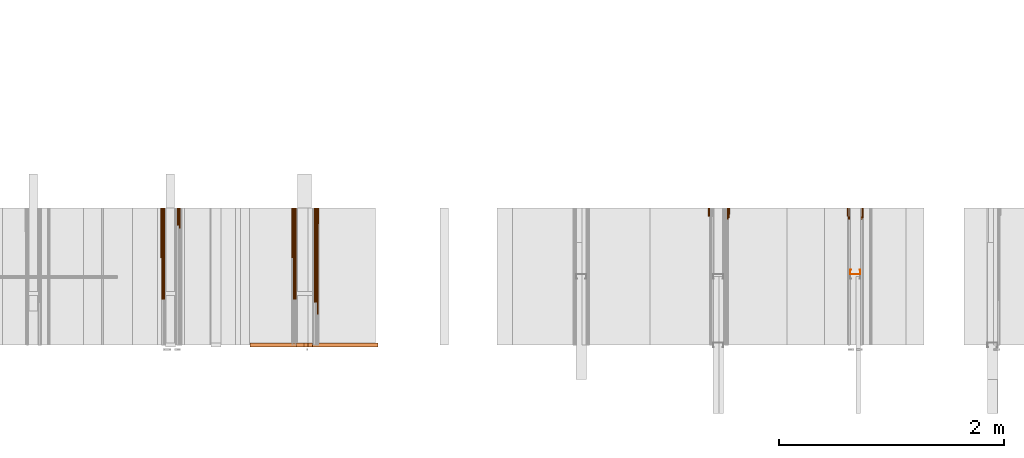
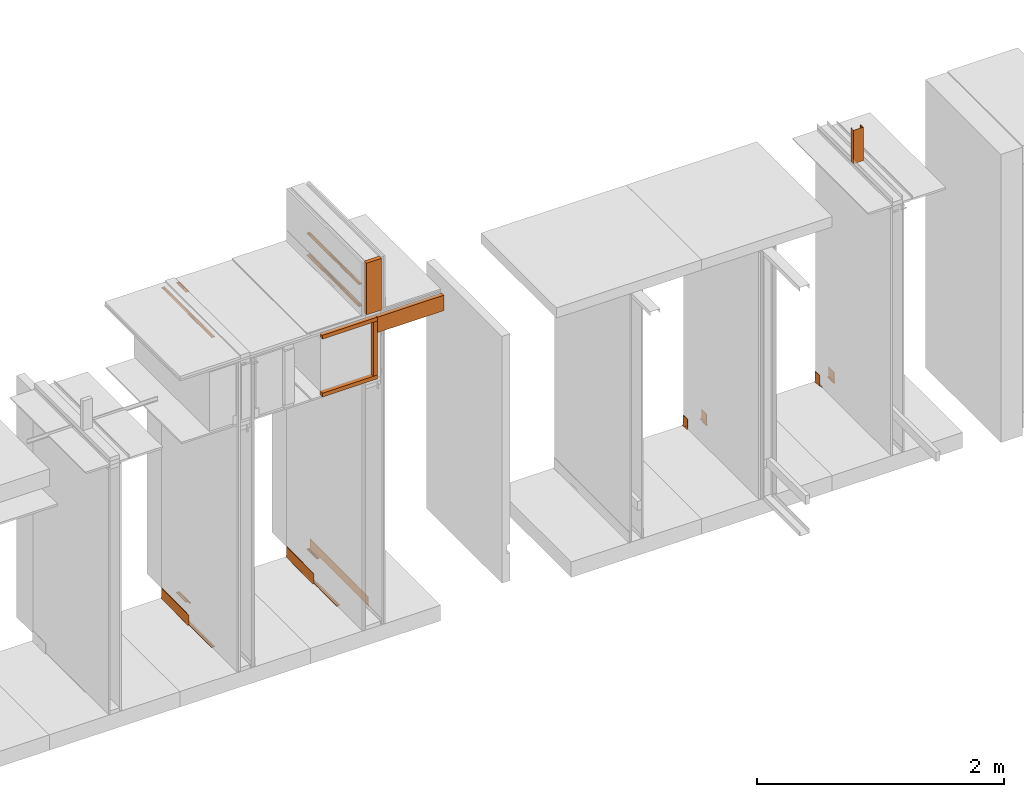
# One storey, part 18 of 38: 32 proxies.
"""IFC4 building model written with IfcOpenShell, lengths in feet."""

from ifc_helpers import new_model, entity, si_unit, converted_unit, frame, origin_with_axes, origin_2d_with_axis, place, context, subcontext, project, spatial, polyline, outline, extrude, material, element, save


model = new_model("IFC4")

# Units and contexts
model_context_1 = context("Model", 3, precision=1e-05, world=origin_with_axes())
plan_context = context("Plan", 2, precision=1e-05, world=origin_2d_with_axis())
model_context_2 = context("Model", 3, precision=1e-05, world=origin_with_axes())
context_of_model_1 = context(None, 3, precision=1e-05, world=origin_with_axes())
context_of_model_2 = context(None, 3, precision=1e-05, world=origin_with_axes())
body_context = subcontext(model_context_2, "Body", "Model", "MODEL_VIEW")
ifc_project = project(units=[converted_unit("PLANEANGLEUNIT", "degree", entity("IfcReal", 0.0174532925199433), si_unit("PLANEANGLEUNIT", "RADIAN"), dimensions=[0, 0, 0, 0, 0, 0, 0]), converted_unit("AREAUNIT", "square foot", entity("IfcReal", 0.09290304), si_unit("AREAUNIT", "SQUARE_METRE"), dimensions=[2, 0, 0, 0, 0, 0, 0]), converted_unit("LENGTHUNIT", "foot", entity("IfcReal", 0.3048), si_unit("LENGTHUNIT", "METRE"), dimensions=[1, 0, 0, 0, 0, 0, 0]), converted_unit("VOLUMEUNIT", "cubic foot", entity("IfcReal", 0.0283168467116885), si_unit("VOLUMEUNIT", "CUBIC_METRE"), dimensions=[3, 0, 0, 0, 0, 0, 0])], contexts=[model_context_1, plan_context, context_of_model_1, context_of_model_2])

# Site, building, storey
site_placement = place(None, origin_with_axes())
site = spatial("IfcSite", under=ifc_project, at=site_placement)
building_placement = place(site_placement, origin_with_axes())
building = spatial("IfcBuilding", under=site, at=building_placement, Name="Building")
storey_placement = place(building_placement, origin_with_axes())
storey = spatial("IfcBuildingStorey", under=building, at=storey_placement, Name="Storey")

# Proxies
for number, where, z_axis, x_axis, name in (
    (1, (1387.44344235718, 5.99999987860051, 9.53906242615908), (4.37113882867379e-08, -0.999999999999999, -8.51092183247426e-15), (1.94707183709394e-07, 0.0, 0.999999999999981), "Generic Models 484:Generic Models 1"),
    (2, (1387.39137824752, 5.99999987860051, 9.53906242615908), (4.37113882867379e-08, -0.999999999999999, -8.51092183247426e-15), (1.94707183709394e-07, 0.0, 0.999999999999981), "Generic Models 485:Generic Models 1"),
):
    element("IfcBuildingElementProxy", number, at=place(storey_placement, frame(where, z_axis=z_axis, x_axis=x_axis)), inside=storey, Name=name, PredefinedType="COMPLEX", context=body_context, shape_type="SweptSolid", body=[
        extrude(outline(polyline([(0.02006640513562, 2.44658686104459e-14), (0.010746400717773, 0.00652686703163065), (0.00925161041627367, 0.0178064079099675), (-0.0174579991570373, 0.00158422270586856), (-0.0159632096194181, -0.00969531779052822), (-0.00664320825709133, -0.0162221848221589), (0.02006640513562, 2.44658686104459e-14)])), frame((0.0104166711240596, -0.0185779741356575, -3.93321257744777e-07), z_axis=(-1.14723248262338e-12, 1.19208920068559e-07, -1.0), x_axis=(0.519110083580017, -0.854707419872284, -1.0188848875714e-07)), (4.71457262118946e-10, 6.21661333521928e-11, -1.0), 2.7499999222411),
    ])
proxy_1_placement = place(storey_placement, frame((1387.2083528774, 1.94270838433363, 9.55989589215577), z_axis=(0.999999999999997, 0.0, 7.54979012640431e-08), x_axis=(7.54979012640431e-08, 0.0, -0.999999999999997)))
element("IfcBuildingElementProxy", 3, at=proxy_1_placement, inside=storey, Name="Generic Models 489:Generic Models 1", PredefinedType="COMPLEX", context=body_context, shape_type="SweptSolid", body=[
    extrude(outline(polyline([(-0.0625000007724355, -0.250000003089742), (0.0625000007724355, -0.250000003089742), (0.0625000007724355, 0.250000003089742), (-0.0625000007724355, 0.250000003089742), (-0.0625000007724355, -0.250000003089742)])), frame((-0.250000003089742, 0.0625000007724355, 1.88745869327634e-08), z_axis=(-7.54979012640433e-08, 0.0, -1.0), x_axis=(0.0, -1.0, 0.0)), (0.0, 3.66200114676474e-09, -1.0), 2.04166679206452),
])
for number, where, z_axis, x_axis, name in (
    (4, (1387.44344235718, 5.99999987860051, 10.2500003466769), (4.37113882867379e-08, -0.999999999999999, -8.51092183247426e-15), (1.94707183709394e-07, 0.0, 0.999999999999981), "Generic Models 494:Generic Models 1"),
    (5, (1387.39137824752, 5.99999987860051, 10.2500003466769), (4.37113882867379e-08, -0.999999999999999, -8.51092183247426e-15), (1.94707183709394e-07, 0.0, 0.999999999999981), "Generic Models 495:Generic Models 1"),
):
    element("IfcBuildingElementProxy", number, at=place(storey_placement, frame(where, z_axis=z_axis, x_axis=x_axis)), inside=storey, Name=name, PredefinedType="COMPLEX", context=body_context, shape_type="SweptSolid", body=[
        extrude(outline(polyline([(0.02006640513562, 2.44658686104459e-14), (0.010746400717773, 0.00652686703163065), (0.00925161041627367, 0.0178064079099675), (-0.0174579991570373, 0.00158422270586856), (-0.0159632096194181, -0.00969531779052822), (-0.00664320825709133, -0.0162221848221589), (0.02006640513562, 2.44658686104459e-14)])), frame((0.0104166711240596, -0.0185779741356575, -3.93321257744777e-07), z_axis=(-1.14723248262338e-12, 1.19208920068559e-07, -1.0), x_axis=(0.519110083580017, -0.854707419872284, -1.0188848875714e-07)), (4.71457262118946e-10, 6.21661333521928e-11, -1.0), 2.7499999222411),
    ])
ifc_material_1 = material(Name="ACOUSTICAL SEALANT OR FIRE SEALANT, IF RATED WALL", Category="sealant")
proxy_2_placement = place(storey_placement, frame((1399.44341864799, 5.99999987860051, 0.0), z_axis=(4.37113882867379e-08, -0.999999999999999, -8.51092183247426e-15), x_axis=(1.94707183709394e-07, 0.0, 0.999999999999981)))
element("IfcBuildingElementProxy", 6, at=proxy_2_placement, inside=storey, material=ifc_material_1, Name="Generic Models 523:Generic Models 1", PredefinedType="COMPLEX", context=body_context, shape_type="SweptSolid", body=[
    extrude(outline(polyline([(0.0175297336061326, -7.63852336224064e-10), (-0.0076045238185586, 0.0185696447874344), (-0.0101125712342697, 0.0074713520236372), (-0.0199842910842085, 0.00181347399851029), (0.0051499686321229, -0.0167561736534743), (0.0150216877181816, -0.0110982950554374), (0.0175297336061326, -7.63852336224064e-10)])), frame((0.0104166703601796, -0.0185779726078973, -3.93321257744777e-07), z_axis=(1.60612517209613e-12, 1.19208898752277e-07, -1.0), x_axis=(0.594228446483612, 0.804296314716339, 9.58789314609021e-08)), (-2.02007854888109e-09, -9.08152775203064e-10, -1.0), 0.327715252322509),
])
ifc_material_2 = material(Name="WALL BASE AS SCHEDULED")
proxy_3_placement = place(storey_placement, frame((1399.47916266174, 5.99999987860051, 0.0), z_axis=(4.37113882867379e-08, -0.999999999999999, -8.51092183247426e-15), x_axis=(1.94707183709394e-07, 0.0, 0.999999999999981)))
element("IfcBuildingElementProxy", 7, at=proxy_3_placement, inside=storey, material=ifc_material_2, Name="Generic Models 524:Generic Models 1", PredefinedType="COMPLEX", context=body_context, shape_type="SweptSolid", body=[
    extrude(outline(polyline([(0.0865199099590616, -4.77471845963041e-10), (0.0968456312310039, -0.00715054454907697), (0.104968817391264, -0.0167299282622189), (0.113724960683994, -0.0110875258742883), (0.103843053729515, 0.000565862347658484), (0.0912817549498219, 0.00926454290576533), (0.0768970805672523, 0.0144157199961502), (0.0616693209240756, 0.0156683458034878), (-0.220639460043019, 0.00187364616797958), (-0.220465197611669, -0.00169230333231194), (-0.218225990145851, -0.00642984586076082), (-0.213292669358216, -0.00819646135544566), (0.0621777106066701, 0.00526409193181636), (0.0746953276687563, 0.00423440222965744), (0.0865199099590616, -4.77471845963041e-10)])), frame((0.113048297389755, -0.0126398416918035, -3.92613465797823e-07), z_axis=(2.34369598381412e-13, 1.19209985882662e-07, -1.0), x_axis=(-0.998808324337006, -0.0488058403134346, -5.81771075758297e-09)), (-0.020832484588027, 0.0165427997708321, -0.999646127223969), 0.287798682010875),
])
proxy_4_placement = place(storey_placement, frame((1398.89264044173, 5.99999987860051, 0.0), z_axis=(4.37113882867379e-08, -0.999999999999999, -8.51092183247426e-15), x_axis=(1.94707183709394e-07, 0.0, 0.999999999999981)))
element("IfcBuildingElementProxy", 8, at=proxy_4_placement, inside=storey, material=ifc_material_2, Name="Generic Models 535:Generic Models 1", PredefinedType="COMPLEX", context=body_context, shape_type="SweptSolid", body=[
    extrude(outline(polyline([(-0.220285068581423, -0.0126398630804453), (0.0623605284947423, -0.0126398630804453), (0.0775090034982664, -0.0106455280636181), (0.091625128205367, -0.00479843599166907), (0.10374691484012, 0.00450294273856568), (0.113048309611836, 0.0166247343385392), (0.10402720382442, 0.0218330687547489), (0.0963812288180424, 0.0118686390730242), (0.0864167983724376, 0.00422266101112633), (0.0748129713097269, -0.000583799731590128), (0.0623605223837018, -0.00222319424802589), (-0.213438576561572, -0.00222319291123578), (-0.218279791746553, -0.00422847681199726), (-0.220285068581423, -0.00906965876819463), (-0.220285068581423, -0.0126398630804453)])), frame((0.113048285167674, -0.0218330458383469, -3.93709398707717e-07), z_axis=(-1.27837871581951e-13, 1.19210028515226e-07, -1.0), x_axis=(-0.999999940395355, -1.94587727264661e-07, -3.29908111463065e-13)), (-0.0198198724538088, -0.0173815358430147, -0.999652445316315), 0.23873268911057),
])
ifc_material_3 = material(Name="ACOUSTICAL SEALANT", Category="sealant")
proxy_5_placement = place(storey_placement, frame((1403.34972872196, 5.99999987860051, 0.0), z_axis=(4.37113882867379e-08, -0.999999999999999, -8.51092183247426e-15), x_axis=(1.94707183709394e-07, 0.0, 0.999999999999981)))
element("IfcBuildingElementProxy", 9, at=proxy_5_placement, inside=storey, material=ifc_material_3, Name="Generic Models 554:Generic Models 1", PredefinedType="COMPLEX", context=body_context, shape_type="SweptSolid", body=[
    extrude(outline(polyline([(0.0175297320783725, -9.54822306813564e-10), (-0.00760452458243866, 0.0185696432596742), (-0.0101125689426295, 0.00747134591259668), (-0.0199842865009281, 0.00181346750552974), (0.00514996939600296, -0.0167561767089946), (0.0150216877181816, -0.0110982973470775), (0.0175297320783725, -9.54822306813564e-10)])), frame((0.0104166718879397, -0.0185779741356575, -3.93321257744777e-07), z_axis=(-2.29446507366698e-13, 1.19208912963131e-07, -1.0), x_axis=(0.594228386878967, 0.804296314716339, 9.58789314609021e-08)), (2.64177368869412e-09, -5.5714988178579e-09, -1.0), 0.327715252322509),
])
proxy_6_placement = place(storey_placement, frame((1402.97917243377, 5.99999987860051, 0.0), z_axis=(4.37113882867379e-08, -0.999999999999999, -8.51092183247426e-15), x_axis=(1.94707183709394e-07, 0.0, 0.999999999999981)))
element("IfcBuildingElementProxy", 10, at=proxy_6_placement, inside=storey, material=ifc_material_1, Name="Generic Models 608:Generic Models 1", PredefinedType="COMPLEX", context=body_context, shape_type="SweptSolid", body=[
    extrude(outline(polyline([(0.0175297320783725, 1.21721940269941e-09), (-0.00760452534631872, 0.0185696447874344), (-0.0101125697065096, 0.00747135049587707), (-0.0199842895564484, 0.00181347361657025), (0.0051499686321229, -0.0167561721257142), (0.0150216861904215, -0.0110982927637972), (0.0175297320783725, 1.21721940269941e-09)])), frame((0.0104166711240596, -0.0171509025657545, -2.04454727426466e-09), z_axis=(-2.15106117596939e-14, 1.19209289550781e-07, -1.0), x_axis=(-0.594228446483612, -0.804296314716339, -9.58795709493643e-08)), (8.53868475925168e-10, 9.09779973579106e-10, -1.0), 0.327715252322509),
])
ifc_material_4 = material(Name="METAL STUD BRACE TO DECK AS")
proxy_7_placement = place(storey_placement, frame((1403.03123654343, 4.06770842281852, 8.2030516909802), z_axis=(0.0, 0.0, 1.0), x_axis=(1.0, 0.0, 0.0)))
element("IfcBuildingElementProxy", 11, at=proxy_7_placement, inside=storey, material=ifc_material_4, Name="Generic Models 610:Generic Models 65", PredefinedType="COMPLEX", context=body_context, shape_type="SweptSolid", body=[
    extrude(outline(polyline([(0.157893092672187, 1.22220810316992e-08), (0.132981448231407, 0.00758804234228735), (0.131463832429701, 0.00260571100971517), (0.151393157759989, -0.00346471323922589), (0.114970610738583, -0.123040630846355), (-0.164039870552973, -0.0380546898334202), (-0.127617323531566, 0.081521225482069), (-0.107687998201278, 0.0754507989414877), (-0.106170394621653, 0.0804331302740599), (-0.131082002396189, 0.0880211481721852), (-0.170539756576846, -0.0415194298084483), (0.11843533849153, -0.129540565758552), (0.157893092672187, 1.22220810316992e-08)])), frame((0.15104167515368, 0.0894097232423586, 0.0), z_axis=(0.0, 0.0, -1.0), x_axis=(-0.956607341766357, 0.291380345821381, 0.0)), (2.82048029376369e-09, 2.82048029376369e-09, -1.0), 1.08333330786739),
])
proxy_8_placement = place(storey_placement, frame((1403.38537261242, 5.99999987860051, 0.0), z_axis=(4.37113882867379e-08, -0.999999999999999, -8.51092183247426e-15), x_axis=(1.94707183709394e-07, 0.0, 0.999999999999981)))
element("IfcBuildingElementProxy", 12, at=proxy_8_placement, inside=storey, material=ifc_material_2, Name="Generic Models 557:Generic Models 1", PredefinedType="COMPLEX", context=body_context, shape_type="SweptSolid", body=[
    extrude(outline(polyline([(0.103844581489644, 6.68348250758758e-10), (0.0913308632714073, 0.00876700184784654), (0.076974470784345, 0.0139964858114015), (0.0617537693929641, 0.015332072049262), (-0.220625991309722, 0.00307591050848599), (-0.220471186431374, -0.000490935787001229), (-0.21825784088902, -0.00524060834893404), (-0.213334248877886, -0.00703408110280597), (0.0622054608416526, 0.00492520150642969), (0.0747172785262892, 0.00382731679345425), (0.0865186083074317, -0.000471456558901934), (0.096805212809032, -0.00767816109289452), (0.104876076240396, -0.017301668046321), (0.113662848068191, -0.0117070593423848), (0.103844581489644, 6.68348250758758e-10)])), frame((0.113048285167674, -0.0126398416918035, -3.92613372550745e-07), z_axis=(-8.52252974139003e-14, 1.19210000093517e-07, -1.0), x_axis=(-0.9990593791008, -0.0433624871075153, -5.16948928108718e-09)), (-0.0207421220839024, 0.0166560765355825, -0.999646127223969), 0.287798682580641),
])
proxy_9_placement = place(storey_placement, frame((1382.9030515015, 5.99999987860051, 0.0), z_axis=(4.37113882867379e-08, -0.999999999999999, -8.51092183247426e-15), x_axis=(1.94707183709394e-07, 0.0, 0.999999999999981)))
element("IfcBuildingElementProxy", 13, at=proxy_9_placement, inside=storey, Name="Generic Models 247:Generic Models 1", PredefinedType="COMPLEX", context=body_context, shape_type="SweptSolid", body=[
    extrude(outline(polyline([(-0.0623605162726613, 0.00222319443899591), (0.213438576561572, 0.00222319443899591), (0.21827976730239, 0.00422847833975739), (0.220285068581423, 0.00906966029595476), (0.220285068581423, 0.0126398615526852), (-0.0623605162726613, 0.0126398600249251), (-0.0775089912761853, 0.0106455280636181), (-0.0916251159832859, 0.00479843599166907), (-0.103746902618039, -0.00450294121080555), (-0.113048285167674, -0.016624732810779), (-0.104027191602339, -0.0218330672269887), (-0.0963812104849208, -0.0118686375452641), (-0.0864167861503566, -0.0042226594833662), (-0.0748129590876459, 0.000583799922560144), (-0.0623605162726613, 0.00222319443899591)])), frame((0.113048285167674, -0.0218330443105868, -3.93709305460639e-07), z_axis=(4.2612652095082e-14, 1.1920982956326e-07, -1.0), x_axis=(1.0, 1.99418224156034e-07, 0.0)), (-0.00616074912250042, -0.000579560699407011, -0.999980926513672), 1.45644764653809),
])
proxy_10_placement = place(storey_placement, frame((1383.44341688582, 5.99999987860051, 10.0416664689232), z_axis=(4.37113882867379e-08, -0.999999999999999, -8.51092183247426e-15), x_axis=(1.94707183709394e-07, 0.0, 0.999999999999981)))
element("IfcBuildingElementProxy", 14, at=proxy_10_placement, inside=storey, Name="Generic Models 365:Generic Models 1", PredefinedType="COMPLEX", context=body_context, shape_type="SweptSolid", body=[
    extrude(outline(polyline([(0.0175297336061326, -4.44417714571301e-10), (0.0150216877181816, 0.0110982950554374), (0.00514996786824283, 0.0167561736534743), (-0.0199842910842085, -0.00181347495336037), (-0.0101125697065096, -0.00747135278751726), (-0.00760452458243866, -0.0185696478429546), (0.0175297336061326, -4.44417714571301e-10)])), frame((0.0104166718879397, -0.0185779726078973, -2.21466728012772e-09), z_axis=(-3.22659176395408e-14, 1.19209289550781e-07, -1.0), x_axis=(-0.594228804111481, 0.804296016693115, 9.58795780547916e-08)), (-0.000335803983034566, 0.000445228302851319, -0.999999821186066), 0.501448011219435),
])
proxy_11_placement = place(storey_placement, frame((1382.9374939125, 5.99999987860051, 10.0416664689232), z_axis=(4.37113882867379e-08, -0.999999999999999, -8.51092183247426e-15), x_axis=(1.94707183709394e-07, 0.0, 0.999999999999981)))
element("IfcBuildingElementProxy", 15, at=proxy_11_placement, inside=storey, Name="Generic Models 367:Generic Models 1", PredefinedType="COMPLEX", context=body_context, shape_type="SweptSolid", body=[
    extrude(outline(polyline([(0.0175297320783725, 1.21719171997307e-09), (-0.00760452534631872, 0.0185696447874344), (-0.0101125697065096, 0.00747135049587707), (-0.0199842895564484, 0.00181347361657025), (0.0051499686321229, -0.0167561721257142), (0.0150216861904215, -0.0110982927637972), (0.0175297320783725, 1.21719171997307e-09)])), frame((0.0104166711240596, -0.0171509025657545, -3.9315117507417e-07), z_axis=(1.14723269946382e-12, 1.19208550586336e-07, -1.0), x_axis=(-0.594228446483612, -0.804296314716339, -9.58762740310704e-08)), (-3.95444403693546e-05, -5.28345335624181e-05, -1.0), 2.66158480628663),
])
proxy_12_placement = place(storey_placement, frame((1383.39135277615, 5.99999987860051, 10.0416664689232), z_axis=(4.37113882867379e-08, -0.999999999999999, -8.51092183247426e-15), x_axis=(1.94707183709394e-07, 0.0, 0.999999999999981)))
element("IfcBuildingElementProxy", 16, at=proxy_12_placement, inside=storey, Name="Generic Models 373:Generic Models 1", PredefinedType="COMPLEX", context=body_context, shape_type="SweptSolid", body=[
    extrude(outline(polyline([(0.0175297336061326, -4.44417714571301e-10), (0.0150216877181816, 0.0110982950554374), (0.00514996786824283, 0.0167561736534743), (-0.0199842910842085, -0.00181347495336037), (-0.0101125697065096, -0.00747135278751726), (-0.00760452458243866, -0.0185696478429546), (0.0175297336061326, -4.44417714571301e-10)])), frame((0.0104166718879397, -0.0185779726078973, -2.21466728012772e-09), z_axis=(-3.22659176395408e-14, 1.19209289550781e-07, -1.0), x_axis=(-0.594228804111481, 0.804296016693115, 9.58795780547916e-08)), (-0.000335803983034566, 0.000445228302851319, -0.999999821186066), 0.501448011219435),
])
proxy_13_placement = place(storey_placement, frame((1382.98955802217, 5.99999987860051, 10.0416664689232), z_axis=(4.37113882867379e-08, -0.999999999999999, -8.51092183247426e-15), x_axis=(1.94707183709394e-07, 0.0, 0.999999999999981)))
element("IfcBuildingElementProxy", 17, at=proxy_13_placement, inside=storey, Name="Generic Models 374:Generic Models 1", PredefinedType="COMPLEX", context=body_context, shape_type="SweptSolid", body=[
    extrude(outline(polyline([(0.0175297320783725, 1.21719171997307e-09), (-0.00760452534631872, 0.0185696447874344), (-0.0101125697065096, 0.00747135049587707), (-0.0199842895564484, 0.00181347361657025), (0.0051499686321229, -0.0167561721257142), (0.0150216861904215, -0.0110982927637972), (0.0175297320783725, 1.21719171997307e-09)])), frame((0.0104166711240596, -0.0171509025657545, -3.9315117507417e-07), z_axis=(1.14723269946382e-12, 1.19208550586336e-07, -1.0), x_axis=(-0.594228446483612, -0.804296314716339, -9.58762740310704e-08)), (-3.95444403693546e-05, -5.28345335624181e-05, -1.0), 2.66158480628663),
])
proxy_14_placement = place(storey_placement, frame((1383.44341688582, 5.99999987860051, 0.0), z_axis=(4.37113882867379e-08, -0.999999999999999, -8.51092183247426e-15), x_axis=(1.94707183709394e-07, 0.0, 0.999999999999981)))
element("IfcBuildingElementProxy", 18, at=proxy_14_placement, inside=storey, Name="Generic Models 375:Generic Models 1", PredefinedType="COMPLEX", context=body_context, shape_type="SweptSolid", body=[
    extrude(outline(polyline([(0.02006640513562, 2.635806462637e-16), (0.010746400717773, 0.00652686703163065), (0.00925161041627367, 0.0178064079099675), (-0.0174579991570373, 0.00158422270586856), (-0.0159632096194181, -0.00969531779052822), (-0.00664320825709133, -0.0162221848221589), (0.02006640513562, 2.635806462637e-16)])), frame((0.0104166711240596, -0.0185779741356575, -2.21466728012772e-09), z_axis=(-3.48427070615692e-14, 1.19209282445354e-07, -1.0), x_axis=(0.519110083580017, -0.854707419872284, -1.01889071402184e-07)), (-1.03517561189648e-09, -1.49884760158869e-09, -0.999999940395355), 0.594568839849673),
])
proxy_15_placement = place(storey_placement, frame((1383.39135277615, 5.99999987860051, 0.0), z_axis=(4.37113882867379e-08, -0.999999999999999, -8.51092183247426e-15), x_axis=(1.94707183709394e-07, 0.0, 0.999999999999981)))
element("IfcBuildingElementProxy", 19, at=proxy_15_placement, inside=storey, Name="Generic Models 376:Generic Models 1", PredefinedType="COMPLEX", context=body_context, shape_type="SweptSolid", body=[
    extrude(outline(polyline([(0.0175297336061326, -4.44417714571301e-10), (0.0150216877181816, 0.0110982950554374), (0.00514996786824283, 0.0167561736534743), (-0.0199842910842085, -0.00181347495336037), (-0.0101125697065096, -0.00747135278751726), (-0.00760452458243866, -0.0185696478429546), (0.0175297336061326, -4.44417714571301e-10)])), frame((0.0104166718879397, -0.0185779726078973, -2.21466728012772e-09), z_axis=(-3.22659176395408e-14, 1.19209289550781e-07, -1.0), x_axis=(-0.594228804111481, 0.804296016693115, 9.58795780547916e-08)), (-0.000335803983034566, 0.000445228302851319, -0.999999821186066), 0.501448011219435),
])
for number, where, z_axis, x_axis, name in (
    (20, (1382.9374939125, 5.99999987860051, 0.0), (4.37113882867379e-08, -0.999999999999999, -8.51092183247426e-15), (1.94707183709394e-07, 0.0, 0.999999999999981), "Generic Models 377:Generic Models 1"),
    (21, (1382.98955802217, 5.99999987860051, 0.0), (4.37113882867379e-08, -0.999999999999999, -8.51092183247426e-15), (1.94707183709394e-07, 0.0, 0.999999999999981), "Generic Models 378:Generic Models 1"),
):
    element("IfcBuildingElementProxy", number, at=place(storey_placement, frame(where, z_axis=z_axis, x_axis=x_axis)), inside=storey, Name=name, PredefinedType="COMPLEX", context=body_context, shape_type="SweptSolid", body=[
        extrude(outline(polyline([(0.0200664036078599, 9.49803628864403e-10), (-0.00664321054873152, 0.0162221848221589), (-0.0159632111471782, 0.00969531626276809), (-0.0174579991570373, -0.00158422404265867), (0.00925161041627367, -0.0178064079099675), (0.010746400717773, -0.00652686703163065), (0.0200664036078599, 9.49803628864403e-10)])), frame((0.0104166703601796, -0.0171509010379943, -3.9315117507417e-07), z_axis=(9.17786246307228e-13, 1.19208571902618e-07, -1.0), x_axis=(0.519109785556793, 0.854707658290863, 1.01890826442741e-07)), (3.46079941664357e-05, 5.61919405299705e-05, -1.0), 2.66158480628662),
    ])
proxy_16_placement = place(storey_placement, frame((1387.47918637093, 5.99999987860051, 0.0), z_axis=(4.37113882867379e-08, -0.999999999999999, -8.51092183247426e-15), x_axis=(1.94707183709394e-07, 0.0, 0.999999999999981)))
element("IfcBuildingElementProxy", 22, at=proxy_16_placement, inside=storey, material=ifc_material_2, Name="Generic Models 445:Generic Models 1", PredefinedType="COMPLEX", context=body_context, shape_type="SweptSolid", body=[
    extrude(outline(polyline([(0.220647404395689, -6.29889932135151e-10), (0.220442880091705, 0.00356434038693569), (0.218163535311779, 0.00828269806756513), (0.213215401361934, 0.0100073574497083), (-0.0621307594823869, -0.00579188951520919), (-0.0746566692264531, -0.00486853115414599), (-0.0865167811063174, -0.000734690297517212), (-0.0969028489033538, 0.00632791332301642), (-0.105107085793976, 0.0158379745383666), (-0.113815000754955, 0.0101214184931765), (-0.103834498272793, -0.00144763436187376), (-0.0911997814523423, -0.0100393357608477), (-0.0767718836802041, -0.015068177458906), (-0.0615340408201762, -0.0161914508716445), (0.220647404395689, -6.29889932135151e-10)])), frame((0.113048297389755, -0.0126398416918035, -3.92613419174284e-07), z_axis=(2.9828852061986e-13, 1.19209985882662e-07, -1.0), x_axis=(0.998357832431793, 0.0572855435311794, 6.82911327487545e-09)), (0.00205389107577503, -0.00259843841195107, -0.999994575977325), 3.10483728625064),
])
proxy_17_placement = place(storey_placement, frame((1386.73637169865, 5.99999987860051, 0.0), z_axis=(4.37113882867379e-08, -0.999999999999999, -8.51092183247426e-15), x_axis=(1.94707183709394e-07, 0.0, 0.999999999999981)))
element("IfcBuildingElementProxy", 23, at=proxy_17_placement, inside=storey, Name="Generic Models 451:Generic Models 1", PredefinedType="COMPLEX", context=body_context, shape_type="SweptSolid", body=[
    extrude(outline(polyline([(0.0748152262836773, 1.14577310893631e-09), (0.0623759527610043, -0.00173651250910376), (-0.213414719059398, -0.0038886410850308), (-0.218240118871524, -0.00593164099106599), (-0.220207605031844, -0.0107883239834718), (-0.220179738687092, -0.014358415241473), (0.0624572357109056, -0.0121528605118961), (0.0775896875661971, -0.010040382276536), (0.0916597594719703, -0.00408331897498409), (0.103708598616086, 0.00531236533249125), (0.112915101150672, 0.0175063695704804), (0.103853638051689, 0.0226441504961745), (0.0962856521443745, 0.0126203612223991), (0.0863811893393518, 0.00489686155603744), (0.0748152262836773, 1.14577310893631e-09)])), frame((0.113048285167674, -0.0218330427828267, -3.93709305460639e-07), z_axis=(1.70450608380328e-13, 1.1920982956326e-07, -1.0), x_axis=(-0.99996954202652, -0.00780344661325216, -9.30411303556866e-10)), (0.00615602871403098, 0.000627616886049509, -0.999980926513672), 1.45644764644443),
])
for number, where, z_axis, x_axis, name in (
    (24, (1387.44344235718, 5.99999987860051, 0.0), (4.37113882867379e-08, -0.999999999999999, -8.51092183247426e-15), (1.94707183709394e-07, 0.0, 0.999999999999981), "Generic Models 465:Generic Models 1"),
    (25, (1387.39137824752, 5.99999987860051, 0.0), (4.37113882867379e-08, -0.999999999999999, -8.51092183247426e-15), (1.94707183709394e-07, 0.0, 0.999999999999981), "Generic Models 466:Generic Models 1"),
):
    element("IfcBuildingElementProxy", number, at=place(storey_placement, frame(where, z_axis=z_axis, x_axis=x_axis)), inside=storey, Name=name, PredefinedType="COMPLEX", context=body_context, shape_type="SweptSolid", body=[
        extrude(outline(polyline([(0.0175297336061326, -4.44445397297637e-10), (0.0150216877181816, 0.0110982950554374), (0.00514996786824283, 0.0167561736534743), (-0.0199842910842085, -0.00181347495336037), (-0.0101125697065096, -0.00747135278751726), (-0.00760452458243866, -0.0185696478429546), (0.0175297336061326, -4.44445397297637e-10)])), frame((0.0104166718879397, -0.0185779726078973, -3.93321257744777e-07), z_axis=(0.0, 1.19208934279413e-07, -1.0), x_axis=(-0.594228804111481, 0.804296016693115, 9.58789385663295e-08)), (-0.000335803983034566, 0.000445228302851319, -0.999999821186066), 0.501448011219435),
    ])
for number, where, z_axis, x_axis, name in (
    (26, (1386.77081410966, 5.99999987860051, 0.0), (4.37113882867379e-08, -0.999999999999999, -8.51092183247426e-15), (1.94707183709394e-07, 0.0, 0.999999999999981), "Generic Models 467:Generic Models 1"),
    (27, (1386.82287821932, 5.99999987860051, 0.0), (4.37113882867379e-08, -0.999999999999999, -8.51092183247426e-15), (1.94707183709394e-07, 0.0, 0.999999999999981), "Generic Models 468:Generic Models 1"),
):
    element("IfcBuildingElementProxy", number, at=place(storey_placement, frame(where, z_axis=z_axis, x_axis=x_axis)), inside=storey, Name=name, PredefinedType="COMPLEX", context=body_context, shape_type="SweptSolid", body=[
        extrude(outline(polyline([(0.0200664036078599, 9.49803628864403e-10), (-0.00664321054873152, 0.0162221848221589), (-0.0159632111471782, 0.00969531626276809), (-0.0174579991570373, -0.00158422404265867), (0.00925161041627367, -0.0178064079099675), (0.010746400717773, -0.00652686703163065), (0.0200664036078599, 9.49803628864403e-10)])), frame((0.0104166703601796, -0.0171509010379943, -3.9315117507417e-07), z_axis=(9.17786246307228e-13, 1.19208571902618e-07, -1.0), x_axis=(0.519109785556793, 0.854707658290863, 1.01890826442741e-07)), (3.46079941664357e-05, 5.61919405299705e-05, -1.0), 2.66158480628662),
    ])
proxy_18_placement = place(storey_placement, frame((1385.51817165585, 1.94270838433363, 8.06249971464863), z_axis=(0.999999999999997, 0.0, 7.54979012640431e-08), x_axis=(7.54979012640431e-08, 0.0, -0.999999999999997)))
element("IfcBuildingElementProxy", 28, at=proxy_18_placement, inside=storey, Name="Generic Models 470:Generic Models 1", PredefinedType="COMPLEX", context=body_context, shape_type="SweptSolid", body=[
    extrude(outline(polyline([(-0.0625000007724355, -0.0625000007724355), (0.0625000007724355, -0.0625000007724355), (0.0625000007724355, 0.0625000007724355), (-0.0625000007724355, 0.0625000007724355), (-0.0625000007724355, -0.0625000007724355)])), frame((-0.0625000007724355, 0.0625000007724355, 4.71862050745011e-09), z_axis=(-7.54979012640433e-08, 0.0, -1.0), x_axis=(1.0, 0.0, -7.54979083694707e-08)), (4.30236929416239e-10, 0.0, -1.0), 1.69017495530587),
])
proxy_19_placement = place(storey_placement, frame((1387.08329889092, 1.94270838433363, 8.18749972841558), z_axis=(0.0, 0.0, 1.0), x_axis=(-1.62920684942944e-07, 0.999999999999987, 0.0)))
element("IfcBuildingElementProxy", 29, at=proxy_19_placement, inside=storey, Name="Generic Models 472:Generic Models 1", PredefinedType="COMPLEX", context=body_context, shape_type="SweptSolid", body=[
    extrude(outline(polyline([(-0.0625000007724355, -0.0625000007724355), (0.0625000007724355, -0.0625000007724355), (0.0625000007724355, 0.0625000007724355), (-0.0625000007724355, 0.0625000007724355), (-0.0625000007724355, -0.0625000007724355)])), frame((0.0625000007724355, -0.0625000007724355, 0.0), z_axis=(0.0, 0.0, -1.0), x_axis=(-1.0, 0.0, 0.0)), (0.0, 0.0, -1.0), 1.74999999899529),
])
proxy_20_placement = place(storey_placement, frame((1385.51817165585, 1.94270838433363, 9.93749992115291), z_axis=(0.999999999999997, 0.0, 7.54979012640431e-08), x_axis=(7.54979012640431e-08, 0.0, -0.999999999999997)))
element("IfcBuildingElementProxy", 30, at=proxy_20_placement, inside=storey, Name="Generic Models 473:Generic Models 1", PredefinedType="COMPLEX", context=body_context, shape_type="SweptSolid", body=[
    extrude(outline(polyline([(-0.0625000007724355, -0.0625000007724355), (0.0625000007724355, -0.0625000007724355), (0.0625000007724355, 0.0625000007724355), (-0.0625000007724355, 0.0625000007724355), (-0.0625000007724355, -0.0625000007724355)])), frame((-0.0625000007724355, 0.0625000007724355, 4.71862050745011e-09), z_axis=(-7.54979012640433e-08, 0.0, -1.0), x_axis=(1.0, 0.0, -7.54979083694707e-08)), (4.30236929416239e-10, 0.0, -1.0), 1.69017495530587),
])
proxy_21_placement = place(storey_placement, frame((1386.87504245227, 5.94270823821621, 10.2500003466769), z_axis=(0.0, -0.999999999999999, -4.37113882867379e-08), x_axis=(1.0, 0.0, 0.0)))
element("IfcBuildingElementProxy", 31, at=proxy_21_placement, inside=storey, Name="Generic Models 478:Generic Models 1", PredefinedType="COMPLEX", context=body_context, shape_type="SweptSolid", body=[
    extrude(outline(polyline([(-0.837337509227863, -0.229166659313863), (0.837337509227863, -0.229166659313863), (0.837337509227863, 0.229166659313863), (-0.837337509227863, 0.229166659313863), (-0.837337509227863, -0.229166659313863)])), frame((0.229166659313863, 0.837337704781159, 3.87499964456233), z_axis=(0.0, 0.0, -1.0), x_axis=(0.0, 1.0, 0.0)), (0.0, 0.0, -1.0), 0.125000015272121),
])
proxy_22_placement = place(storey_placement, frame((1402.94473002276, 5.99999987860051, 0.0), z_axis=(4.37113882867379e-08, -0.999999999999999, -8.51092183247426e-15), x_axis=(1.94707183709394e-07, 0.0, 0.999999999999981)))
element("IfcBuildingElementProxy", 32, at=proxy_22_placement, inside=storey, material=ifc_material_2, Name="Generic Models 586:Generic Models 1", PredefinedType="COMPLEX", context=body_context, shape_type="SweptSolid", body=[
    extrude(outline(polyline([(0.0748152262836773, 1.1458197324754e-09), (0.0623759527610043, -0.00173651250910376), (-0.213414719059398, -0.0038886410850308), (-0.218240118871524, -0.00593164099106599), (-0.220207605031844, -0.0107883239834718), (-0.220179738687092, -0.014358415241473), (0.0624572357109056, -0.0121528605118961), (0.0775896875661971, -0.010040382276536), (0.0916597594719703, -0.00408331897498409), (0.103708598616086, 0.00531236533249125), (0.112915101150672, 0.0175063695704804), (0.103853638051689, 0.0226441504961745), (0.0962856521443745, 0.0126203612223991), (0.0863811893393518, 0.00489686155603744), (0.0748152262836773, 1.1458197324754e-09)])), frame((0.113048285167674, -0.0218330427828267, -2.60270516133657e-09), z_axis=(-3.02949329576523e-14, 1.19209289550781e-07, -1.0), x_axis=(-0.99996954202652, -0.00780344661325216, -9.30211685457039e-10)), (-0.0196836031973362, -0.0175356585532427, -0.999652445316315), 0.238732688926038),
])

save(model, "model.ifc")
